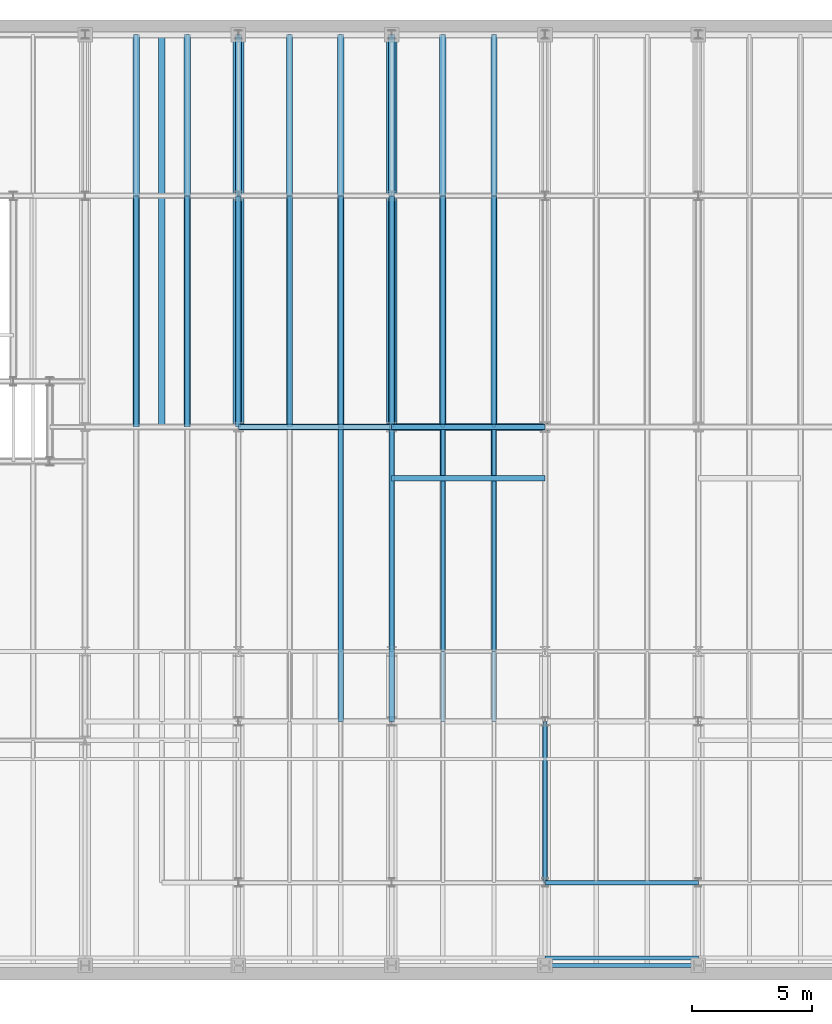
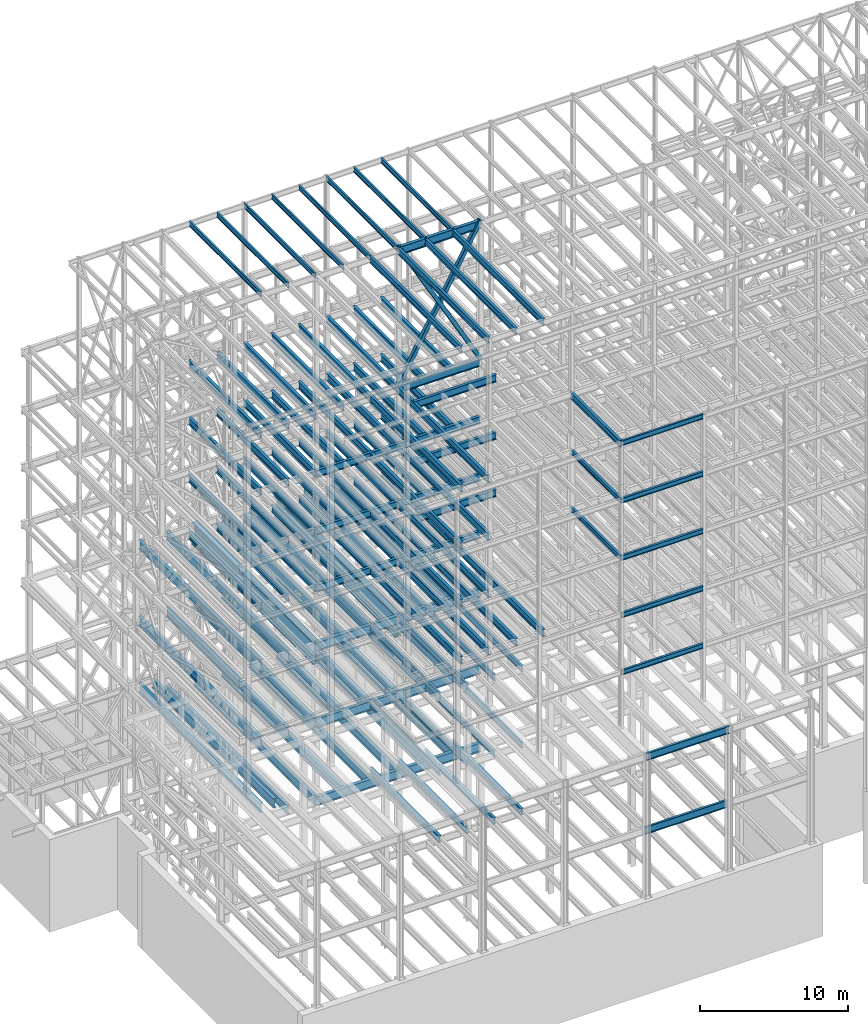
# One storey, part 128 of 150: 120 beams.
"""IFC2X3 building model written with IfcOpenShell, lengths in millimetres."""

from ifc_helpers import new_model, si_unit, frame, origin_with_axes, origin_2d_with_axis, place, context, subcontext, project, spatial, hollow_rectangle, i_section, extrude, material, type_object, element, save


model = new_model("IFC2X3")

# Units and contexts
model_context = context("Model", 3, precision=1e-05, world=origin_with_axes())
body_context = subcontext(model_context, "Body", "Model", "MODEL_VIEW")
ifc_project = project(units=[si_unit("LENGTHUNIT", "METRE", prefix="MILLI"), si_unit("AREAUNIT", "SQUARE_METRE"), si_unit("VOLUMEUNIT", "CUBIC_METRE"), si_unit("MASSUNIT", "GRAM", prefix="KILO"), si_unit("TIMEUNIT", "SECOND"), si_unit("PLANEANGLEUNIT", "RADIAN"), si_unit("SOLIDANGLEUNIT", "STERADIAN"), si_unit("THERMODYNAMICTEMPERATUREUNIT", "DEGREE_CELSIUS"), si_unit("LUMINOUSINTENSITYUNIT", "LUMEN")], contexts=[model_context])

# Site, building, storey
site_placement = place(None, origin_with_axes())
site = spatial("IfcSite", under=ifc_project, at=site_placement, CompositionType="ELEMENT")
building_placement = place(site_placement, origin_with_axes())
building = spatial("IfcBuilding", under=site, at=building_placement, Name="Undefined", CompositionType="ELEMENT")
storey_placement = place(building_placement, origin_with_axes())
storey = spatial("IfcBuildingStorey", under=building, at=storey_placement, Name="Undefined", CompositionType="ELEMENT", Elevation=0.0)

# Beams
ifc_material_1 = material(Name="STEEL/A992")
beam_type_1 = type_object("IfcBeamType", PredefinedType="NOTDEFINED")
for number, where, z_axis, x_axis, name in (
    (1, (18186.4, 22479.0, 34671.0), (0.0, 0.0, 1.0), (0.0, 1.0, 0.0), "BEAM"),
    (2, (24587.2, 22479.0, 34671.0), (0.0, 0.0, 1.0), (0.0, 1.0, 0.0), "BEAM"),
):
    element("IfcBeam", number, at=place(storey_placement, frame(where, z_axis=z_axis, x_axis=x_axis)), inside=storey, type_object=beam_type_1, material=ifc_material_1, Name=name, context=body_context, shape_type="SweptSolid", body=[
        extrude(i_section(OverallWidth=457.2, OverallDepth=1828.8, WebThickness=44.45, FlangeThickness=88.9, FilletRadius=31.115, at=origin_2d_with_axis()), frame((16383.0, 0.0, 0.0), z_axis=(-1.0, 0.0, 0.0), x_axis=(0.0, -1.0, 0.0)), (0.0, 0.0, 1.0), 16383.0),
    ])
ifc_material_2 = material()
beam_type_2 = type_object("IfcBeamType", Name="HSS12X12X3/8", PredefinedType="NOTDEFINED")
for number, where, z_axis, x_axis, name in (
    (3, (30988.0, 22479.0, 54483.0), (0.872506041528282, 0.0, 0.488603323255837), (-0.488603323255836, 0.0, 0.872506041528283), "BEAM"),
    (4, (24587.2, 22479.0, 54483.0), (-0.872506041528282, 0.0, 0.488603323255837), (0.488603323255836, 0.0, 0.872506041528283), "BEAM"),
):
    element("IfcBeam", number, at=place(storey_placement, frame(where, z_axis=z_axis, x_axis=x_axis)), inside=storey, type_object=beam_type_2, material=ifc_material_2, Name=name, ObjectType="HSS12X12X3/8", context=body_context, shape_type="SweptSolid", body=[
        extrude(hollow_rectangle(XDim=304.8, YDim=304.8, WallThickness=9.525, InnerFilletRadius=9.5249, OuterFilletRadius=19.0499, at=origin_2d_with_axis()), frame((13100.1962061642, 3.63797880709171e-12, 0.0), z_axis=(-1.0, 0.0, 0.0), x_axis=(0.0, -1.0, 0.0)), (0.0, 0.0, 1.0), 13100.1962061642),
    ])
beam_type_3 = type_object("IfcBeamType", Name="W16X31", PredefinedType="NOTDEFINED")
for number, where, z_axis, x_axis, name in (
    (5, (28854.4, 22479.0, 65711.3875), (0.0, 0.0, 1.0), (0.0, 1.0, 0.0), "BEAM"),
    (6, (26720.8, 22479.0, 65711.3875), (0.0, 0.0, 1.0), (0.0, 1.0, 0.0), "BEAM"),
    (7, (24587.2, 22479.0, 65711.3875), (0.0, 0.0, 1.0), (0.0, 1.0, 0.0), "BEAM"),
    (8, (22453.6, 22479.0, 65711.3875), (0.0, 0.0, 1.0), (0.0, 1.0, 0.0), "BEAM"),
    (9, (20320.0, 22479.0, 65711.3875), (0.0, 0.0, 1.0), (0.0, 1.0, 0.0), "BEAM"),
    (10, (18186.4, 22479.0, 65711.3875), (0.0, 0.0, 1.0), (0.0, 1.0, 0.0), "BEAM"),
    (11, (16052.8, 22479.0, 65711.3875), (0.0, 0.0, 1.0), (0.0, 1.0, 0.0), "BEAM"),
    (12, (13919.2, 22479.0, 65711.3875), (0.0, 0.0, 1.0), (0.0, 1.0, 0.0), "BEAM"),
):
    element("IfcBeam", number, at=place(storey_placement, frame(where, z_axis=z_axis, x_axis=x_axis)), inside=storey, type_object=beam_type_3, material=ifc_material_1, Name=name, ObjectType="W16X31", context=body_context, shape_type="SweptSolid", body=[
        extrude(i_section(OverallWidth=140.462, OverallDepth=403.225, WebThickness=6.3499, FlangeThickness=11.176, FilletRadius=17.399, at=origin_2d_with_axis()), frame((9652.0, 0.0, 0.0), z_axis=(-1.0, 0.0, 0.0), x_axis=(0.0, -1.0, 0.0)), (0.0, 0.0, 1.0), 9652.0),
    ])
beam_1_placement = place(storey_placement, frame((30988.0, 3454.4, 59005.7875), z_axis=(0.0, 0.0, 1.0), x_axis=(1.0, 0.0, 0.0)))
element("IfcBeam", 13, at=beam_1_placement, inside=storey, type_object=beam_type_3, material=ifc_material_1, Name="BEAM", ObjectType="W16X31", context=body_context, shape_type="SweptSolid", body=[
    extrude(i_section(OverallWidth=140.462, OverallDepth=403.225, WebThickness=6.3499, FlangeThickness=11.176, FilletRadius=17.399, at=origin_2d_with_axis()), frame((6400.80000000001, 0.0, 0.0), z_axis=(-1.0, 0.0, 0.0), x_axis=(0.0, -1.0, 0.0)), (0.0, 0.0, 1.0), 6400.80000000001),
])
beam_type_4 = type_object("IfcBeamType", Name="W24X68", PredefinedType="NOTDEFINED")
beam_2_placement = place(storey_placement, frame((24587.2, 20345.4, 54181.375), z_axis=(0.0, 0.0, 1.0), x_axis=(1.0, 0.0, 0.0)))
element("IfcBeam", 14, at=beam_2_placement, inside=storey, type_object=beam_type_4, material=ifc_material_1, Name="BEAM", ObjectType="W24X68", context=body_context, shape_type="SweptSolid", body=[
    extrude(i_section(OverallWidth=227.838, OverallDepth=603.25, WebThickness=11.1125, FlangeThickness=14.859, FilletRadius=23.2409, at=origin_2d_with_axis()), frame((6400.80000000001, 0.0, 0.0), z_axis=(-1.0, 0.0, 0.0), x_axis=(0.0, -1.0, 0.0)), (0.0, 0.0, 1.0), 6400.8),
])
for number, where, z_axis, x_axis, name in (
    (15, (28854.4, 22479.0, 54181.375), (0.0, 0.0, 1.0), (0.0, 1.0, 0.0), "BEAM"),
    (16, (26720.8, 22479.0, 54181.375), (0.0, 0.0, 1.0), (0.0, 1.0, 0.0), "BEAM"),
    (17, (24587.2, 22479.0, 54181.375), (0.0, 0.0, 1.0), (0.0, 1.0, 0.0), "BEAM"),
    (18, (22453.6, 22479.0, 54181.375), (0.0, 0.0, 1.0), (0.0, 1.0, 0.0), "BEAM"),
    (19, (20320.0, 22479.0, 54181.375), (0.0, 0.0, 1.0), (0.0, 1.0, 0.0), "BEAM"),
    (20, (18186.4, 22479.0, 54181.375), (0.0, 0.0, 1.0), (0.0, 1.0, 0.0), "BEAM"),
    (21, (16052.8, 22479.0, 54181.375), (0.0, 0.0, 1.0), (0.0, 1.0, 0.0), "BEAM"),
    (22, (13919.2, 22479.0, 54181.375), (0.0, 0.0, 1.0), (0.0, 1.0, 0.0), "BEAM"),
):
    element("IfcBeam", number, at=place(storey_placement, frame(where, z_axis=z_axis, x_axis=x_axis)), inside=storey, type_object=beam_type_4, material=ifc_material_1, Name=name, ObjectType="W24X68", context=body_context, shape_type="SweptSolid", body=[
        extrude(i_section(OverallWidth=227.838, OverallDepth=603.25, WebThickness=11.1125, FlangeThickness=14.859, FilletRadius=23.2409, at=origin_2d_with_axis()), frame((9652.0, 0.0, 0.0), z_axis=(-1.0, 0.0, 0.0), x_axis=(0.0, -1.0, 0.0)), (0.0, 0.0, 1.0), 9652.0),
    ])
for number, where, z_axis, x_axis, name in (
    (23, (24587.2, 10185.4, 54181.375), (0.0, 0.0, 1.0), (0.0, 1.0, 0.0), "BEAM"),
    (24, (22453.6, 10185.4, 54181.375), (0.0, 0.0, 1.0), (0.0, 1.0, 0.0), "BEAM"),
):
    element("IfcBeam", number, at=place(storey_placement, frame(where, z_axis=z_axis, x_axis=x_axis)), inside=storey, type_object=beam_type_4, material=ifc_material_1, Name=name, ObjectType="W24X68", context=body_context, shape_type="SweptSolid", body=[
        extrude(i_section(OverallWidth=227.838, OverallDepth=603.25, WebThickness=11.1125, FlangeThickness=14.859, FilletRadius=23.2409, at=origin_2d_with_axis()), frame((12293.6, 0.0, 0.0), z_axis=(-1.0, 0.0, 0.0), x_axis=(0.0, -1.0, 0.0)), (0.0, 0.0, 1.0), 12293.6),
    ])
for number, where, z_axis, x_axis, name in (
    (25, (24587.2, 20345.4, 49456.975), (0.0, 0.0, 1.0), (1.0, 0.0, 0.0), "BEAM"),
    (26, (24587.2, 22479.0, 49456.975), (0.0, 0.0, 1.0), (1.0, 0.0, 0.0), "BEAM"),
):
    element("IfcBeam", number, at=place(storey_placement, frame(where, z_axis=z_axis, x_axis=x_axis)), inside=storey, type_object=beam_type_4, material=ifc_material_1, Name=name, ObjectType="W24X68", context=body_context, shape_type="SweptSolid", body=[
        extrude(i_section(OverallWidth=227.838, OverallDepth=603.25, WebThickness=11.1125, FlangeThickness=14.859, FilletRadius=23.2409, at=origin_2d_with_axis()), frame((6400.80000000001, 0.0, 0.0), z_axis=(-1.0, 0.0, 0.0), x_axis=(0.0, -1.0, 0.0)), (0.0, 0.0, 1.0), 6400.8),
    ])
for number, where, z_axis, x_axis, name in (
    (27, (28854.4, 22479.0, 49456.975), (0.0, 0.0, 1.0), (0.0, 1.0, 0.0), "BEAM"),
    (28, (26720.8, 22479.0, 49456.975), (0.0, 0.0, 1.0), (0.0, 1.0, 0.0), "BEAM"),
    (29, (24587.2, 22479.0, 49456.975), (0.0, 0.0, 1.0), (0.0, 1.0, 0.0), "BEAM"),
):
    element("IfcBeam", number, at=place(storey_placement, frame(where, z_axis=z_axis, x_axis=x_axis)), inside=storey, type_object=beam_type_4, material=ifc_material_1, Name=name, ObjectType="W24X68", context=body_context, shape_type="SweptSolid", body=[
        extrude(i_section(OverallWidth=227.838, OverallDepth=603.25, WebThickness=11.1125, FlangeThickness=14.859, FilletRadius=23.2409, at=origin_2d_with_axis()), frame((9652.0, 0.0, 0.0), z_axis=(-1.0, 0.0, 0.0), x_axis=(0.0, -1.0, 0.0)), (0.0, 0.0, 1.0), 9652.0),
    ])
beam_3_placement = place(storey_placement, frame((18186.4, 22479.0, 49456.975), z_axis=(0.0, 0.0, 1.0), x_axis=(1.0, 0.0, 0.0)))
element("IfcBeam", 30, at=beam_3_placement, inside=storey, type_object=beam_type_4, material=ifc_material_1, Name="BEAM", ObjectType="W24X68", context=body_context, shape_type="SweptSolid", body=[
    extrude(i_section(OverallWidth=227.838, OverallDepth=603.25, WebThickness=11.1125, FlangeThickness=14.859, FilletRadius=23.2409, at=origin_2d_with_axis()), frame((6400.80000000001, 0.0, 0.0), z_axis=(-1.0, 0.0, 0.0), x_axis=(0.0, -1.0, 0.0)), (0.0, 0.0, 1.0), 6400.8),
])
for number, where, z_axis, x_axis, name in (
    (31, (22453.6, 22479.0, 49456.975), (0.0, 0.0, 1.0), (0.0, 1.0, 0.0), "BEAM"),
    (32, (20320.0, 22479.0, 49456.975), (0.0, 0.0, 1.0), (0.0, 1.0, 0.0), "BEAM"),
    (33, (18186.4, 22479.0, 49456.975), (0.0, 0.0, 1.0), (0.0, 1.0, 0.0), "BEAM"),
    (34, (16052.8, 22479.0, 49456.975), (0.0, 0.0, 1.0), (0.0, 1.0, 0.0), "BEAM"),
    (35, (13919.2, 22479.0, 49456.975), (0.0, 0.0, 1.0), (0.0, 1.0, 0.0), "BEAM"),
):
    element("IfcBeam", number, at=place(storey_placement, frame(where, z_axis=z_axis, x_axis=x_axis)), inside=storey, type_object=beam_type_4, material=ifc_material_1, Name=name, ObjectType="W24X68", context=body_context, shape_type="SweptSolid", body=[
        extrude(i_section(OverallWidth=227.838, OverallDepth=603.25, WebThickness=11.1125, FlangeThickness=14.859, FilletRadius=23.2409, at=origin_2d_with_axis()), frame((9652.0, 0.0, 0.0), z_axis=(-1.0, 0.0, 0.0), x_axis=(0.0, -1.0, 0.0)), (0.0, 0.0, 1.0), 9652.0),
    ])
for number, where, z_axis, x_axis, name in (
    (36, (24587.2, 10185.4, 49456.975), (0.0, 0.0, 1.0), (0.0, 1.0, 0.0), "BEAM"),
    (37, (22453.6, 10185.4, 49456.975), (0.0, 0.0, 1.0), (0.0, 1.0, 0.0), "BEAM"),
):
    element("IfcBeam", number, at=place(storey_placement, frame(where, z_axis=z_axis, x_axis=x_axis)), inside=storey, type_object=beam_type_4, material=ifc_material_1, Name=name, ObjectType="W24X68", context=body_context, shape_type="SweptSolid", body=[
        extrude(i_section(OverallWidth=227.838, OverallDepth=603.25, WebThickness=11.1125, FlangeThickness=14.859, FilletRadius=23.2409, at=origin_2d_with_axis()), frame((12293.6, 0.0, 0.0), z_axis=(-1.0, 0.0, 0.0), x_axis=(0.0, -1.0, 0.0)), (0.0, 0.0, 1.0), 12293.6),
    ])
for number, where, z_axis, x_axis, name in (
    (38, (24587.2, 20345.4, 44732.575), (0.0, 0.0, 1.0), (1.0, 0.0, 0.0), "BEAM"),
    (39, (24587.2, 22479.0, 44732.575), (0.0, 0.0, 1.0), (1.0, 0.0, 0.0), "BEAM"),
):
    element("IfcBeam", number, at=place(storey_placement, frame(where, z_axis=z_axis, x_axis=x_axis)), inside=storey, type_object=beam_type_4, material=ifc_material_1, Name=name, ObjectType="W24X68", context=body_context, shape_type="SweptSolid", body=[
        extrude(i_section(OverallWidth=227.838, OverallDepth=603.25, WebThickness=11.1125, FlangeThickness=14.859, FilletRadius=23.2409, at=origin_2d_with_axis()), frame((6400.80000000001, 0.0, 0.0), z_axis=(-1.0, 0.0, 0.0), x_axis=(0.0, -1.0, 0.0)), (0.0, 0.0, 1.0), 6400.8),
    ])
for number, where, z_axis, x_axis, name in (
    (40, (28854.4, 22479.0, 44732.575), (0.0, 0.0, 1.0), (0.0, 1.0, 0.0), "BEAM"),
    (41, (26720.8, 22479.0, 44732.575), (0.0, 0.0, 1.0), (0.0, 1.0, 0.0), "BEAM"),
    (42, (24587.2, 22479.0, 44732.575), (0.0, 0.0, 1.0), (0.0, 1.0, 0.0), "BEAM"),
):
    element("IfcBeam", number, at=place(storey_placement, frame(where, z_axis=z_axis, x_axis=x_axis)), inside=storey, type_object=beam_type_4, material=ifc_material_1, Name=name, ObjectType="W24X68", context=body_context, shape_type="SweptSolid", body=[
        extrude(i_section(OverallWidth=227.838, OverallDepth=603.25, WebThickness=11.1125, FlangeThickness=14.859, FilletRadius=23.2409, at=origin_2d_with_axis()), frame((9652.0, 0.0, 0.0), z_axis=(-1.0, 0.0, 0.0), x_axis=(0.0, -1.0, 0.0)), (0.0, 0.0, 1.0), 9652.0),
    ])
beam_4_placement = place(storey_placement, frame((18186.4, 22479.0, 44732.575), z_axis=(0.0, 0.0, 1.0), x_axis=(1.0, 0.0, 0.0)))
element("IfcBeam", 43, at=beam_4_placement, inside=storey, type_object=beam_type_4, material=ifc_material_1, Name="BEAM", ObjectType="W24X68", context=body_context, shape_type="SweptSolid", body=[
    extrude(i_section(OverallWidth=227.838, OverallDepth=603.25, WebThickness=11.1125, FlangeThickness=14.859, FilletRadius=23.2409, at=origin_2d_with_axis()), frame((6400.80000000001, 0.0, 0.0), z_axis=(-1.0, 0.0, 0.0), x_axis=(0.0, -1.0, 0.0)), (0.0, 0.0, 1.0), 6400.8),
])
for number, where, z_axis, x_axis, name in (
    (44, (22453.6, 22479.0, 44732.575), (0.0, 0.0, 1.0), (0.0, 1.0, 0.0), "BEAM"),
    (45, (20320.0, 22479.0, 44732.575), (0.0, 0.0, 1.0), (0.0, 1.0, 0.0), "BEAM"),
    (46, (18186.4, 22479.0, 44732.575), (0.0, 0.0, 1.0), (0.0, 1.0, 0.0), "BEAM"),
    (47, (16052.8, 22479.0, 44732.575), (0.0, 0.0, 1.0), (0.0, 1.0, 0.0), "BEAM"),
    (48, (13919.2, 22479.0, 44732.575), (0.0, 0.0, 1.0), (0.0, 1.0, 0.0), "BEAM"),
):
    element("IfcBeam", number, at=place(storey_placement, frame(where, z_axis=z_axis, x_axis=x_axis)), inside=storey, type_object=beam_type_4, material=ifc_material_1, Name=name, ObjectType="W24X68", context=body_context, shape_type="SweptSolid", body=[
        extrude(i_section(OverallWidth=227.838, OverallDepth=603.25, WebThickness=11.1125, FlangeThickness=14.859, FilletRadius=23.2409, at=origin_2d_with_axis()), frame((9652.0, 0.0, 0.0), z_axis=(-1.0, 0.0, 0.0), x_axis=(0.0, -1.0, 0.0)), (0.0, 0.0, 1.0), 9652.0),
    ])
for number, where, z_axis, x_axis, name in (
    (49, (24587.2, 10185.4, 44732.575), (0.0, 0.0, 1.0), (0.0, 1.0, 0.0), "BEAM"),
    (50, (22453.6, 10185.4, 44732.575), (0.0, 0.0, 1.0), (0.0, 1.0, 0.0), "BEAM"),
):
    element("IfcBeam", number, at=place(storey_placement, frame(where, z_axis=z_axis, x_axis=x_axis)), inside=storey, type_object=beam_type_4, material=ifc_material_1, Name=name, ObjectType="W24X68", context=body_context, shape_type="SweptSolid", body=[
        extrude(i_section(OverallWidth=227.838, OverallDepth=603.25, WebThickness=11.1125, FlangeThickness=14.859, FilletRadius=23.2409, at=origin_2d_with_axis()), frame((12293.6, 0.0, 0.0), z_axis=(-1.0, 0.0, 0.0), x_axis=(0.0, -1.0, 0.0)), (0.0, 0.0, 1.0), 12293.6),
    ])
beam_5_placement = place(storey_placement, frame((24587.2, 22479.0, 40008.175), z_axis=(0.0, 0.0, 1.0), x_axis=(1.0, 0.0, 0.0)))
element("IfcBeam", 51, at=beam_5_placement, inside=storey, type_object=beam_type_4, material=ifc_material_1, Name="BEAM", ObjectType="W24X68", context=body_context, shape_type="SweptSolid", body=[
    extrude(i_section(OverallWidth=227.838, OverallDepth=603.25, WebThickness=11.1125, FlangeThickness=14.859, FilletRadius=23.2409, at=origin_2d_with_axis()), frame((6400.80000000001, 0.0, 0.0), z_axis=(-1.0, 0.0, 0.0), x_axis=(0.0, -1.0, 0.0)), (0.0, 0.0, 1.0), 6400.8),
])
for number, where, z_axis, x_axis, name in (
    (52, (28854.4, 22479.0, 40008.175), (0.0, 0.0, 1.0), (0.0, 1.0, 0.0), "BEAM"),
    (53, (26720.8, 22479.0, 40008.175), (0.0, 0.0, 1.0), (0.0, 1.0, 0.0), "BEAM"),
    (54, (24587.2, 22479.0, 40008.175), (0.0, 0.0, 1.0), (0.0, 1.0, 0.0), "BEAM"),
):
    element("IfcBeam", number, at=place(storey_placement, frame(where, z_axis=z_axis, x_axis=x_axis)), inside=storey, type_object=beam_type_4, material=ifc_material_1, Name=name, ObjectType="W24X68", context=body_context, shape_type="SweptSolid", body=[
        extrude(i_section(OverallWidth=227.838, OverallDepth=603.25, WebThickness=11.1125, FlangeThickness=14.859, FilletRadius=23.2409, at=origin_2d_with_axis()), frame((9652.0, 0.0, 0.0), z_axis=(-1.0, 0.0, 0.0), x_axis=(0.0, -1.0, 0.0)), (0.0, 0.0, 1.0), 9652.0),
    ])
beam_6_placement = place(storey_placement, frame((18186.4, 22479.0, 40008.175), z_axis=(0.0, 0.0, 1.0), x_axis=(1.0, 0.0, 0.0)))
element("IfcBeam", 55, at=beam_6_placement, inside=storey, type_object=beam_type_4, material=ifc_material_1, Name="BEAM", ObjectType="W24X68", context=body_context, shape_type="SweptSolid", body=[
    extrude(i_section(OverallWidth=227.838, OverallDepth=603.25, WebThickness=11.1125, FlangeThickness=14.859, FilletRadius=23.2409, at=origin_2d_with_axis()), frame((6400.80000000001, 0.0, 0.0), z_axis=(-1.0, 0.0, 0.0), x_axis=(0.0, -1.0, 0.0)), (0.0, 0.0, 1.0), 6400.8),
])
for number, where, z_axis, x_axis, name in (
    (56, (22453.6, 22479.0, 40008.175), (0.0, 0.0, 1.0), (0.0, 1.0, 0.0), "BEAM"),
    (57, (20320.0, 22479.0, 40008.175), (0.0, 0.0, 1.0), (0.0, 1.0, 0.0), "BEAM"),
    (58, (18186.4, 22479.0, 40008.175), (0.0, 0.0, 1.0), (0.0, 1.0, 0.0), "BEAM"),
    (59, (16052.8, 22479.0, 40008.175), (0.0, 0.0, 1.0), (0.0, 1.0, 0.0), "BEAM"),
    (60, (13919.2, 22479.0, 40008.175), (0.0, 0.0, 1.0), (0.0, 1.0, 0.0), "BEAM"),
):
    element("IfcBeam", number, at=place(storey_placement, frame(where, z_axis=z_axis, x_axis=x_axis)), inside=storey, type_object=beam_type_4, material=ifc_material_1, Name=name, ObjectType="W24X68", context=body_context, shape_type="SweptSolid", body=[
        extrude(i_section(OverallWidth=227.838, OverallDepth=603.25, WebThickness=11.1125, FlangeThickness=14.859, FilletRadius=23.2409, at=origin_2d_with_axis()), frame((9652.0, 0.0, 0.0), z_axis=(-1.0, 0.0, 0.0), x_axis=(0.0, -1.0, 0.0)), (0.0, 0.0, 1.0), 9652.0),
    ])
for number, where, z_axis, x_axis, name in (
    (61, (28854.4, 10185.4, 40008.175), (0.0, 0.0, 1.0), (0.0, 1.0, 0.0), "BEAM"),
    (62, (26720.8, 10185.4, 40008.175), (0.0, 0.0, 1.0), (0.0, 1.0, 0.0), "BEAM"),
    (63, (24587.2, 10185.4, 40008.175), (0.0, 0.0, 1.0), (0.0, 1.0, 0.0), "BEAM"),
    (64, (22453.6, 10185.4, 40008.175), (0.0, 0.0, 1.0), (0.0, 1.0, 0.0), "BEAM"),
):
    element("IfcBeam", number, at=place(storey_placement, frame(where, z_axis=z_axis, x_axis=x_axis)), inside=storey, type_object=beam_type_4, material=ifc_material_1, Name=name, ObjectType="W24X68", context=body_context, shape_type="SweptSolid", body=[
        extrude(i_section(OverallWidth=227.838, OverallDepth=603.25, WebThickness=11.1125, FlangeThickness=14.859, FilletRadius=23.2409, at=origin_2d_with_axis()), frame((12293.6, 0.0, 0.0), z_axis=(-1.0, 0.0, 0.0), x_axis=(0.0, -1.0, 0.0)), (0.0, 0.0, 1.0), 12293.6),
    ])
beam_type_5 = type_object("IfcBeamType", Name="W21X55", PredefinedType="NOTDEFINED")
for number, where, z_axis, x_axis, name in (
    (65, (22453.6, 10185.4, 65649.475), (0.0, 0.0, 1.0), (0.0, 1.0, 0.0), "BEAM"),
    (66, (28854.4, 10185.4, 65649.475), (0.0, 0.0, 1.0), (0.0, 1.0, 0.0), "BEAM"),
    (67, (26720.8, 10185.4, 65649.475), (0.0, 0.0, 1.0), (0.0, 1.0, 0.0), "BEAM"),
    (68, (24587.2, 10185.4, 65649.475), (0.0, 0.0, 1.0), (0.0, 1.0, 0.0), "BEAM"),
):
    element("IfcBeam", number, at=place(storey_placement, frame(where, z_axis=z_axis, x_axis=x_axis)), inside=storey, type_object=beam_type_5, material=ifc_material_1, Name=name, ObjectType="W21X55", context=body_context, shape_type="SweptSolid", body=[
        extrude(i_section(OverallWidth=208.788, OverallDepth=527.05, WebThickness=9.5, FlangeThickness=13.2588, FilletRadius=16.8624, at=origin_2d_with_axis()), frame((12293.6, 0.0, 0.0), z_axis=(-1.0, 0.0, 0.0), x_axis=(0.0, -1.0, 0.0)), (0.0, 0.0, 1.0), 12293.6),
    ])
beam_7_placement = place(storey_placement, frame((30988.0, 3454.4, 58943.875), z_axis=(0.0, 0.0, 1.0), x_axis=(0.0, 1.0, 0.0)))
element("IfcBeam", 69, at=beam_7_placement, inside=storey, type_object=beam_type_5, material=ifc_material_1, Name="BEAM", ObjectType="W21X55", context=body_context, shape_type="SweptSolid", body=[
    extrude(i_section(OverallWidth=208.788, OverallDepth=527.05, WebThickness=9.5, FlangeThickness=13.2588, FilletRadius=16.8624, at=origin_2d_with_axis()), frame((6731.0, 0.0, 0.0), z_axis=(-1.0, 0.0, 0.0), x_axis=(0.0, -1.0, 0.0)), (0.0, 0.0, 1.0), 6731.0),
])
beam_type_6 = type_object("IfcBeamType", Name="W27X84", PredefinedType="NOTDEFINED")
beam_8_placement = place(storey_placement, frame((24587.2, 22479.0, 65573.275), z_axis=(0.0, 0.0, 1.0), x_axis=(1.0, 0.0, 0.0)))
element("IfcBeam", 70, at=beam_8_placement, inside=storey, type_object=beam_type_6, material=ifc_material_1, Name="BEAM", ObjectType="W27X84", context=body_context, shape_type="SweptSolid", body=[
    extrude(i_section(OverallWidth=254.0, OverallDepth=679.45, WebThickness=11.1125, FlangeThickness=16.256, FilletRadius=23.4314, at=origin_2d_with_axis()), frame((6400.80000000001, 0.0, 0.0), z_axis=(-1.0, 0.0, 0.0), x_axis=(0.0, -1.0, 0.0)), (0.0, 0.0, 1.0), 6400.8),
])
beam_type_7 = type_object("IfcBeamType", Name="W24X76", PredefinedType="NOTDEFINED")
beam_9_placement = place(storey_placement, frame((24587.2, 22479.0, 54179.7875), z_axis=(0.0, 0.0, 1.0), x_axis=(1.0, 0.0, 0.0)))
element("IfcBeam", 71, at=beam_9_placement, inside=storey, type_object=beam_type_7, material=ifc_material_1, Name="BEAM", ObjectType="W24X76", context=body_context, shape_type="SweptSolid", body=[
    extrude(i_section(OverallWidth=228.346, OverallDepth=606.425, WebThickness=11.1125, FlangeThickness=17.272, FilletRadius=22.4155, at=origin_2d_with_axis()), frame((6400.80000000001, 0.0, 0.0), z_axis=(-1.0, 0.0, 0.0), x_axis=(0.0, -1.0, 0.0)), (0.0, 0.0, 1.0), 6400.8),
])
beam_type_8 = type_object("IfcBeamType", Name="W21X44", PredefinedType="NOTDEFINED")
for number, where, z_axis, x_axis, name in (
    (72, (22453.6, 13106.4, 35323.4625), (0.0, 0.0, 1.0), (0.0, 1.0, 0.0), "BEAM"),
    (73, (24587.2, 13106.4, 35323.4625), (0.0, 0.0, 1.0), (0.0, 1.0, 0.0), "BEAM"),
    (74, (26720.8, 13106.4, 35323.4625), (0.0, 0.0, 1.0), (0.0, 1.0, 0.0), "BEAM"),
    (75, (28854.4, 13106.4, 35323.4625), (0.0, 0.0, 1.0), (0.0, 1.0, 0.0), "BEAM"),
    (76, (28854.4, 13106.4, 29024.2625), (0.0, 0.0, 1.0), (0.0, 1.0, 0.0), "BEAM"),
    (77, (26720.8, 13106.4, 29024.2625), (0.0, 0.0, 1.0), (0.0, 1.0, 0.0), "BEAM"),
    (78, (24587.2, 13106.4, 29024.2625), (0.0, 0.0, 1.0), (0.0, 1.0, 0.0), "BEAM"),
    (79, (22453.6, 13106.4, 29024.2625), (0.0, 0.0, 1.0), (0.0, 1.0, 0.0), "BEAM"),
):
    element("IfcBeam", number, at=place(storey_placement, frame(where, z_axis=z_axis, x_axis=x_axis)), inside=storey, type_object=beam_type_8, material=ifc_material_1, Name=name, ObjectType="W21X44", context=body_context, shape_type="SweptSolid", body=[
        extrude(i_section(OverallWidth=165.1, OverallDepth=523.875, WebThickness=9.5249, FlangeThickness=11.43, FilletRadius=17.145, at=origin_2d_with_axis()), frame((9372.6, 0.0, 0.0), z_axis=(-1.0, 0.0, 0.0), x_axis=(0.0, -1.0, 0.0)), (0.0, 0.0, 1.0), 9372.6),
    ])
beam_type_9 = type_object("IfcBeamType", Name="W16X36", PredefinedType="NOTDEFINED")
beam_10_placement = place(storey_placement, frame((30988.0, 3454.4, 54281.3875), z_axis=(0.0, 0.0, 1.0), x_axis=(1.0, 0.0, 0.0)))
element("IfcBeam", 80, at=beam_10_placement, inside=storey, type_object=beam_type_9, material=ifc_material_1, Name="BEAM", ObjectType="W16X36", context=body_context, shape_type="SweptSolid", body=[
    extrude(i_section(OverallWidth=177.8, OverallDepth=403.225, WebThickness=7.9375, FlangeThickness=10.922, FilletRadius=17.6529, at=origin_2d_with_axis()), frame((6400.80000000001, 0.0, 0.0), z_axis=(-1.0, 0.0, 0.0), x_axis=(0.0, -1.0, 0.0)), (0.0, 0.0, 1.0), 6400.8),
])
beam_11_placement = place(storey_placement, frame((30988.0, 3454.4, 54281.3875), z_axis=(0.0, 0.0, 1.0), x_axis=(0.0, 1.0, 0.0)))
element("IfcBeam", 81, at=beam_11_placement, inside=storey, type_object=beam_type_9, material=ifc_material_1, Name="BEAM", ObjectType="W16X36", context=body_context, shape_type="SweptSolid", body=[
    extrude(i_section(OverallWidth=177.8, OverallDepth=403.225, WebThickness=7.9375, FlangeThickness=10.922, FilletRadius=17.6529, at=origin_2d_with_axis()), frame((6731.0, 0.0, 0.0), z_axis=(-1.0, 0.0, 0.0), x_axis=(0.0, -1.0, 0.0)), (0.0, 0.0, 1.0), 6731.0),
])
beam_12_placement = place(storey_placement, frame((30988.0, 3454.4, 49556.9875), z_axis=(0.0, 0.0, 1.0), x_axis=(1.0, 0.0, 0.0)))
element("IfcBeam", 82, at=beam_12_placement, inside=storey, type_object=beam_type_9, material=ifc_material_1, Name="BEAM", ObjectType="W16X36", context=body_context, shape_type="SweptSolid", body=[
    extrude(i_section(OverallWidth=177.8, OverallDepth=403.225, WebThickness=7.9375, FlangeThickness=10.922, FilletRadius=17.6529, at=origin_2d_with_axis()), frame((6400.80000000001, 0.0, 0.0), z_axis=(-1.0, 0.0, 0.0), x_axis=(0.0, -1.0, 0.0)), (0.0, 0.0, 1.0), 6400.8),
])
beam_13_placement = place(storey_placement, frame((30988.0, 3454.4, 49556.9875), z_axis=(0.0, 0.0, 1.0), x_axis=(0.0, 1.0, 0.0)))
element("IfcBeam", 83, at=beam_13_placement, inside=storey, type_object=beam_type_9, material=ifc_material_1, Name="BEAM", ObjectType="W16X36", context=body_context, shape_type="SweptSolid", body=[
    extrude(i_section(OverallWidth=177.8, OverallDepth=403.225, WebThickness=7.9375, FlangeThickness=10.922, FilletRadius=17.6529, at=origin_2d_with_axis()), frame((6731.0, 0.0, 0.0), z_axis=(-1.0, 0.0, 0.0), x_axis=(0.0, -1.0, 0.0)), (0.0, 0.0, 1.0), 6731.0),
])
for number, where, z_axis, x_axis, name in (
    (84, (30988.0, 3454.4, 44832.5875), (0.0, 0.0, 1.0), (1.0, 0.0, 0.0), "BEAM"),
    (85, (30988.0, 3454.4, 40108.1875), (0.0, 0.0, 1.0), (1.0, 0.0, 0.0), "BEAM"),
):
    element("IfcBeam", number, at=place(storey_placement, frame(where, z_axis=z_axis, x_axis=x_axis)), inside=storey, type_object=beam_type_9, material=ifc_material_1, Name=name, ObjectType="W16X36", context=body_context, shape_type="SweptSolid", body=[
        extrude(i_section(OverallWidth=177.8, OverallDepth=403.225, WebThickness=7.9375, FlangeThickness=10.922, FilletRadius=17.6529, at=origin_2d_with_axis()), frame((6400.80000000001, 0.0, 0.0), z_axis=(-1.0, 0.0, 0.0), x_axis=(0.0, -1.0, 0.0)), (0.0, 0.0, 1.0), 6400.8),
    ])
beam_type_10 = type_object("IfcBeamType", Name="W24X62", PredefinedType="NOTDEFINED")
for number, where, z_axis, x_axis, name in (
    (86, (30988.0, 0.0, 35283.775), (0.0, 0.0, 1.0), (1.0, 0.0, 0.0), "BEAM"),
    (87, (30988.0, 304.8, 28984.575), (0.0, 0.0, 1.0), (1.0, 0.0, 0.0), "BEAM"),
):
    element("IfcBeam", number, at=place(storey_placement, frame(where, z_axis=z_axis, x_axis=x_axis)), inside=storey, type_object=beam_type_10, material=ifc_material_1, Name=name, ObjectType="W24X62", context=body_context, shape_type="SweptSolid", body=[
        extrude(i_section(OverallWidth=177.8, OverallDepth=603.25, WebThickness=11.1125, FlangeThickness=14.986, FilletRadius=23.114, at=origin_2d_with_axis()), frame((6400.80000000001, 0.0, 0.0), z_axis=(-1.0, 0.0, 0.0), x_axis=(0.0, -1.0, 0.0)), (0.0, 0.0, 1.0), 6400.8),
    ])
beam_type_11 = type_object("IfcBeamType", Name="W30X90", PredefinedType="NOTDEFINED")
for number, where, z_axis, x_axis, name in (
    (88, (28854.4, 22479.0, 35210.75), (0.0, 0.0, 1.0), (0.0, 1.0, 0.0), "BEAM"),
    (89, (26720.8, 22479.0, 35210.75), (0.0, 0.0, 1.0), (0.0, 1.0, 0.0), "BEAM"),
    (90, (22453.6, 22479.0, 35210.75), (0.0, 0.0, 1.0), (0.0, 1.0, 0.0), "BEAM"),
    (91, (20320.0, 22479.0, 35210.75), (0.0, 0.0, 1.0), (0.0, 1.0, 0.0), "BEAM"),
    (92, (16052.8, 22479.0, 35210.75), (0.0, 0.0, 1.0), (0.0, 1.0, 0.0), "BEAM"),
    (93, (13919.2, 22479.0, 35210.75), (0.0, 0.0, 1.0), (0.0, 1.0, 0.0), "BEAM"),
):
    element("IfcBeam", number, at=place(storey_placement, frame(where, z_axis=z_axis, x_axis=x_axis)), inside=storey, type_object=beam_type_11, material=ifc_material_1, Name=name, ObjectType="W30X90", context=body_context, shape_type="SweptSolid", body=[
        extrude(i_section(OverallWidth=264.16, OverallDepth=749.3, WebThickness=12.6999, FlangeThickness=15.494, FilletRadius=22.606, at=origin_2d_with_axis()), frame((16383.0, 0.0, 0.0), z_axis=(-1.0, 0.0, 0.0), x_axis=(0.0, -1.0, 0.0)), (0.0, 0.0, 1.0), 16383.0),
    ])
for number, where, z_axis, x_axis, name in (
    (94, (24587.2, 22479.0, 35210.75), (0.0, 0.0, 1.0), (1.0, 0.0, 0.0), "BEAM"),
    (95, (18186.4, 22479.0, 35210.75), (0.0, 0.0, 1.0), (1.0, 0.0, 0.0), "BEAM"),
):
    element("IfcBeam", number, at=place(storey_placement, frame(where, z_axis=z_axis, x_axis=x_axis)), inside=storey, type_object=beam_type_11, material=ifc_material_1, Name=name, ObjectType="W30X90", context=body_context, shape_type="SweptSolid", body=[
        extrude(i_section(OverallWidth=264.16, OverallDepth=749.3, WebThickness=12.6999, FlangeThickness=15.494, FilletRadius=22.606, at=origin_2d_with_axis()), frame((6400.80000000001, 0.0, 0.0), z_axis=(-1.0, 0.0, 0.0), x_axis=(0.0, -1.0, 0.0)), (0.0, 0.0, 1.0), 6400.8),
    ])
for number, where, z_axis, x_axis, name in (
    (96, (28854.4, 22479.0, 28911.55), (0.0, 0.0, 1.0), (0.0, 1.0, 0.0), "BEAM"),
    (97, (26720.8, 22479.0, 28911.55), (0.0, 0.0, 1.0), (0.0, 1.0, 0.0), "BEAM"),
    (98, (24587.2, 22479.0, 28911.55), (0.0, 0.0, 1.0), (0.0, 1.0, 0.0), "BEAM"),
    (99, (22453.6, 22479.0, 28911.55), (0.0, 0.0, 1.0), (0.0, 1.0, 0.0), "BEAM"),
    (100, (20320.0, 22479.0, 28911.55), (0.0, 0.0, 1.0), (0.0, 1.0, 0.0), "BEAM"),
    (101, (18186.4, 22479.0, 28911.55), (0.0, 0.0, 1.0), (0.0, 1.0, 0.0), "BEAM"),
    (102, (16052.8, 22479.0, 28911.55), (0.0, 0.0, 1.0), (0.0, 1.0, 0.0), "BEAM"),
    (103, (13919.2, 22479.0, 28911.55), (0.0, 0.0, 1.0), (0.0, 1.0, 0.0), "BEAM"),
):
    element("IfcBeam", number, at=place(storey_placement, frame(where, z_axis=z_axis, x_axis=x_axis)), inside=storey, type_object=beam_type_11, material=ifc_material_1, Name=name, ObjectType="W30X90", context=body_context, shape_type="SweptSolid", body=[
        extrude(i_section(OverallWidth=264.16, OverallDepth=749.3, WebThickness=12.6999, FlangeThickness=15.494, FilletRadius=22.606, at=origin_2d_with_axis()), frame((16383.0, 0.0, 0.0), z_axis=(-1.0, 0.0, 0.0), x_axis=(0.0, -1.0, 0.0)), (0.0, 0.0, 1.0), 16383.0),
    ])
for number, where, z_axis, x_axis, name in (
    (104, (24587.2, 22479.0, 28911.55), (0.0, 0.0, 1.0), (1.0, 0.0, 0.0), "BEAM"),
    (105, (18186.4, 22479.0, 28911.55), (0.0, 0.0, 1.0), (1.0, 0.0, 0.0), "BEAM"),
):
    element("IfcBeam", number, at=place(storey_placement, frame(where, z_axis=z_axis, x_axis=x_axis)), inside=storey, type_object=beam_type_11, material=ifc_material_1, Name=name, ObjectType="W30X90", context=body_context, shape_type="SweptSolid", body=[
        extrude(i_section(OverallWidth=264.16, OverallDepth=749.3, WebThickness=12.6999, FlangeThickness=15.494, FilletRadius=22.606, at=origin_2d_with_axis()), frame((6400.80000000001, 0.0, 0.0), z_axis=(-1.0, 0.0, 0.0), x_axis=(0.0, -1.0, 0.0)), (0.0, 0.0, 1.0), 6400.8),
    ])
for number, where, z_axis, x_axis, name in (
    (106, (13919.2, 22479.0, 23399.75), (0.0, 0.0, 1.0), (0.0, 1.0, 0.0), "BEAM"),
    (107, (28854.4, 22479.0, 22485.35), (0.0, 0.0, 1.0), (0.0, 1.0, 0.0), "BEAM"),
    (108, (26720.8, 22479.0, 22485.35), (0.0, 0.0, 1.0), (0.0, 1.0, 0.0), "BEAM"),
    (109, (24587.2, 22479.0, 22485.35), (0.0, 0.0, 1.0), (0.0, 1.0, 0.0), "BEAM"),
    (110, (22453.6, 22479.0, 22485.35), (0.0, 0.0, 1.0), (0.0, 1.0, 0.0), "BEAM"),
    (111, (20320.0, 22479.0, 22485.35), (0.0, 0.0, 1.0), (0.0, 1.0, 0.0), "BEAM"),
    (112, (18186.4, 22479.0, 22485.35), (0.0, 0.0, 1.0), (0.0, 1.0, 0.0), "BEAM"),
    (113, (16052.8, 22479.0, 22485.35), (0.0, 0.0, 1.0), (0.0, 1.0, 0.0), "BEAM"),
    (114, (14986.0, 22479.0, 23399.75), (0.0, 0.0, 1.0), (0.0, 1.0, 0.0), "BEAM"),
):
    element("IfcBeam", number, at=place(storey_placement, frame(where, z_axis=z_axis, x_axis=x_axis)), inside=storey, type_object=beam_type_11, material=ifc_material_1, Name=name, ObjectType="W30X90", context=body_context, shape_type="SweptSolid", body=[
        extrude(i_section(OverallWidth=264.16, OverallDepth=749.3, WebThickness=12.6999, FlangeThickness=15.494, FilletRadius=22.606, at=origin_2d_with_axis()), frame((16383.0, 0.0, 0.0), z_axis=(-1.0, 0.0, 0.0), x_axis=(0.0, -1.0, 0.0)), (0.0, 0.0, 1.0), 16383.0),
    ])
for number, where, z_axis, x_axis, name in (
    (115, (24587.2, 22479.0, 22485.35), (0.0, 0.0, 1.0), (1.0, 0.0, 0.0), "BEAM"),
    (116, (18186.4, 22479.0, 22485.35), (0.0, 0.0, 1.0), (1.0, 0.0, 0.0), "BEAM"),
):
    element("IfcBeam", number, at=place(storey_placement, frame(where, z_axis=z_axis, x_axis=x_axis)), inside=storey, type_object=beam_type_11, material=ifc_material_1, Name=name, ObjectType="W30X90", context=body_context, shape_type="SweptSolid", body=[
        extrude(i_section(OverallWidth=264.16, OverallDepth=749.3, WebThickness=12.6999, FlangeThickness=15.494, FilletRadius=22.606, at=origin_2d_with_axis()), frame((6400.80000000001, 0.0, 0.0), z_axis=(-1.0, 0.0, 0.0), x_axis=(0.0, -1.0, 0.0)), (0.0, 0.0, 1.0), 6400.8),
    ])
beam_type_12 = type_object("IfcBeamType", Name="W21X73", PredefinedType="NOTDEFINED")
for number, where, z_axis, x_axis, name in (
    (117, (28854.4, 13106.4, 23504.525), (0.0, 0.0, 1.0), (0.0, 1.0, 0.0), "BEAM"),
    (118, (26720.8, 13106.4, 23504.525), (0.0, 0.0, 1.0), (0.0, 1.0, 0.0), "BEAM"),
    (119, (24587.2, 13106.4, 23504.525), (0.0, 0.0, 1.0), (0.0, 1.0, 0.0), "BEAM"),
    (120, (22453.6, 13106.4, 23504.525), (0.0, 0.0, 1.0), (0.0, 1.0, 0.0), "BEAM"),
):
    element("IfcBeam", number, at=place(storey_placement, frame(where, z_axis=z_axis, x_axis=x_axis)), inside=storey, type_object=beam_type_12, material=ifc_material_1, Name=name, ObjectType="W21X73", context=body_context, shape_type="SweptSolid", body=[
        extrude(i_section(OverallWidth=209.55, OverallDepth=539.75, WebThickness=11.1125, FlangeThickness=18.796, FilletRadius=17.7164, at=origin_2d_with_axis()), frame((9372.6, 0.0, 0.0), z_axis=(-1.0, 0.0, 0.0), x_axis=(0.0, -1.0, 0.0)), (0.0, 0.0, 1.0), 9372.6),
    ])

save(model, "model.ifc")
